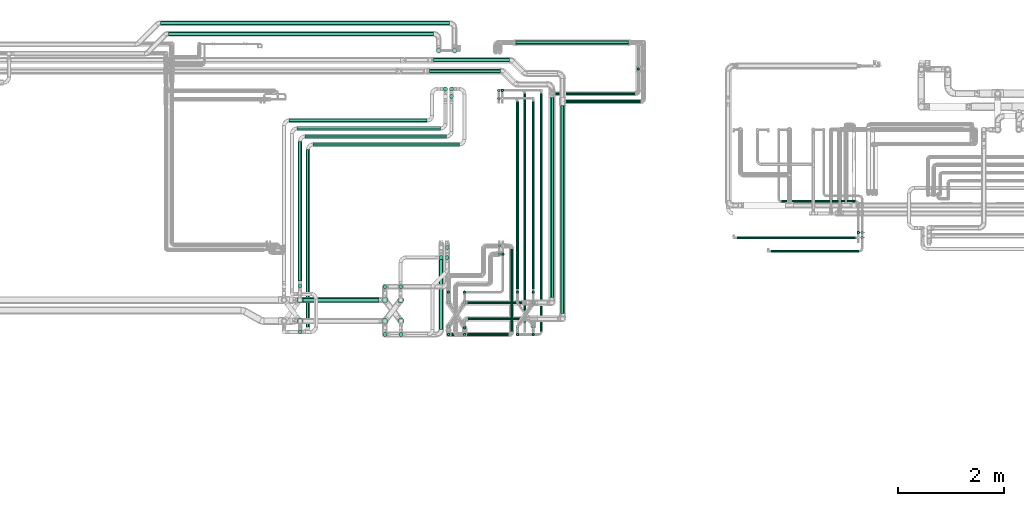
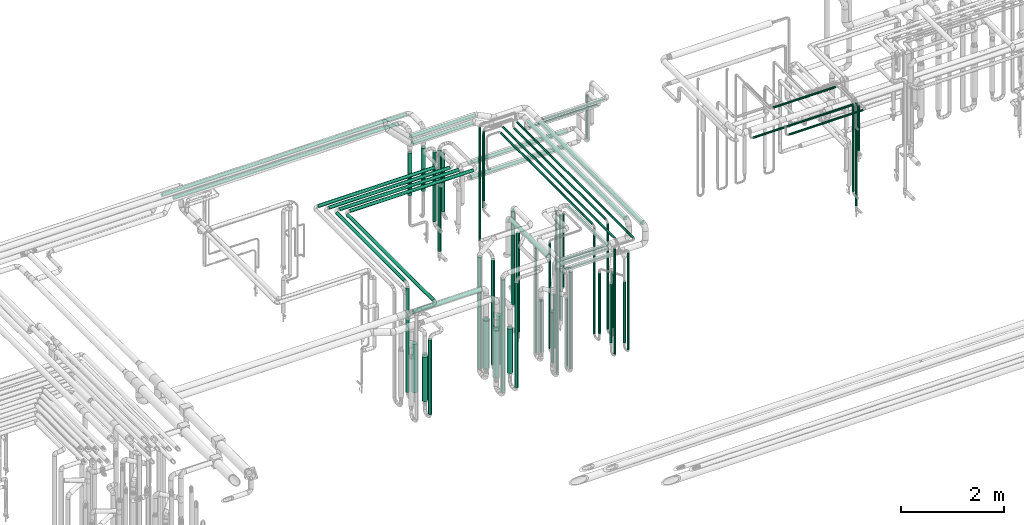
# One storey, part 540 of 827: 75 flow segments.
"""IFC2X3 building model written with IfcOpenShell, lengths in millimetres."""

import ifcopenshell
import ifcopenshell.guid

model = None  # the IFC model being written
_history = None  # IfcOwnerHistory: only IFC2X3 demands one
_inside = {}  # id of a spatial element -> (the spatial element, [elements in it])
_under = {}  # id of a project, library or spatial element -> (it, [spatial elements below it])
_declared = {}  # id of a project -> (the project, [libraries it declares])
_typed = {}  # id of a type object -> (the type object, [elements of that type])
_made_of = {}  # id of a material, layer set ... -> (it, [elements and type objects made of it])


def new_model(schema):
    """Start an empty IFC model of exactly this schema.

    Asked for "IFC4X3", IfcOpenShell would pick the latest addendum, in which some entities
    have other attributes; the version numbers below select the first issue.
    IFC2X3 requires an IfcOwnerHistory on every rooted entity: one is made here for all.
    """
    global model, _history
    if schema == "IFC4X3":
        model = ifcopenshell.file(schema_version=(4, 3, 0, 0))
    else:
        model = ifcopenshell.file(schema=schema)
    _inside.clear()
    _under.clear()
    _declared.clear()
    _typed.clear()
    _made_of.clear()
    _history = None
    if model.schema == "IFC2X3":
        org = make("IfcOrganization", Name="unknown")
        user = make(
            "IfcPersonAndOrganization",
            ThePerson=make("IfcPerson", FamilyName="unknown"),
            TheOrganization=org,
        )
        app = make(
            "IfcApplication",
            ApplicationDeveloper=org,
            Version="unknown",
            ApplicationFullName="unknown",
            ApplicationIdentifier="unknown",
        )
        _history = make(
            "IfcOwnerHistory",
            OwningUser=user,
            OwningApplication=app,
            ChangeAction="ADDED",
            CreationDate=0,
        )
    return model


def make(cls, **values):
    """One entity of the class cls with the attributes given. An attribute that is None is left unset."""
    return model.create_entity(
        cls, **{name: value for name, value in values.items() if value is not None}
    )


def entity(cls, *values):
    """Any entity or typed value of the class cls, its attributes in the order of the schema. None: left unset."""
    e = model.create_entity(cls)
    for i, value in enumerate(values):
        if value is not None:
            e[i] = value
    return e


def rooted(cls, **values):
    """An entity with a GlobalId (a new one), such as an element, a storey or a relation."""
    return make(cls, GlobalId=ifcopenshell.guid.new(), OwnerHistory=_history, **values)


def si_unit(unit_type, name, prefix=None):
    """IfcSIUnit, for example si_unit("LENGTHUNIT", "METRE", prefix="MILLI")."""
    return make("IfcSIUnit", UnitType=unit_type, Prefix=prefix, Name=name)


def converted_unit(unit_type, name, factor, base, dimensions=None, offset=None):
    """IfcConversionBasedUnit, such as the inch: factor (a typed value) times the base unit."""
    return make(
        "IfcConversionBasedUnit"
        if offset is None
        else "IfcConversionBasedUnitWithOffset",
        ConversionOffset=offset,
        Dimensions=None
        if dimensions is None
        else entity("IfcDimensionalExponents", *dimensions),
        UnitType=unit_type,
        Name=name,
        ConversionFactor=make(
            "IfcMeasureWithUnit", ValueComponent=factor, UnitComponent=base
        ),
    )


def derived_unit(unit_type, elements):
    """IfcDerivedUnit: a product of units, each with its exponent."""
    return make(
        "IfcDerivedUnit",
        Elements=[
            make("IfcDerivedUnitElement", Unit=unit, Exponent=power)
            for unit, power in elements
        ],
        UnitType=unit_type,
    )


def assignment(units):
    """IfcUnitAssignment: the units of a project."""
    return None if units is None else make("IfcUnitAssignment", Units=units)


def point(xyz):
    """IfcCartesianPoint."""
    return None if xyz is None else make("IfcCartesianPoint", Coordinates=xyz)


def direction(xyz):
    """IfcDirection."""
    return None if xyz is None else make("IfcDirection", DirectionRatios=xyz)


def frame(location, z_axis=None, x_axis=None):
    """IfcAxis2Placement3D, a coordinate frame: its origin and axes. An axis left out is left unset."""
    return make(
        "IfcAxis2Placement3D",
        Location=point(location),
        Axis=direction(z_axis),
        RefDirection=direction(x_axis),
    )


def frame_2d(location, x_axis=None):
    """IfcAxis2Placement2D, a coordinate frame in the plane: its origin and x axis."""
    return make(
        "IfcAxis2Placement2D", Location=point(location), RefDirection=direction(x_axis)
    )


def origin():
    """The frame at (0, 0, 0) with its axes left unset."""
    return frame((0.0, 0.0, 0.0))


def origin_2d_with_axis():
    """The frame at (0, 0) in the plane with the x axis (1, 0) written out."""
    return frame_2d((0.0, 0.0), x_axis=(1.0, 0.0))


def place(relative_to, where):
    """IfcLocalPlacement: puts the frame where relative to a parent placement (None: the world)."""
    return make(
        "IfcLocalPlacement", PlacementRelTo=relative_to, RelativePlacement=where
    )


def context(
    kind, dimensions, precision=None, world=None, true_north=None, identifier=None
):
    """IfcGeometricRepresentationContext, for example the 3D "Model" context."""
    return make(
        "IfcGeometricRepresentationContext",
        ContextIdentifier=identifier,
        ContextType=kind,
        CoordinateSpaceDimension=dimensions,
        Precision=precision,
        WorldCoordinateSystem=world,
        TrueNorth=true_north,
    )


def subcontext(parent, identifier, kind, view, scale=None):
    """IfcGeometricRepresentationSubContext, for example "Body" below "Model"."""
    return make(
        "IfcGeometricRepresentationSubContext",
        ContextIdentifier=identifier,
        ContextType=kind,
        ParentContext=parent,
        TargetScale=scale,
        TargetView=view,
    )


def project(units=None, contexts=None):
    """IfcProject with its units and contexts."""
    return rooted(
        "IfcProject",
        Name="project",
        RepresentationContexts=contexts,
        UnitsInContext=assignment(units),
    )


def spatial(cls, under=None, at=None, **own):
    """A site, building, storey or space (cls), placed at a placement, below another one or the project."""
    s = rooted(cls, ObjectPlacement=at, **own)
    if under is not None:
        _under.setdefault(under.id(), (under, []))[1].append(s)
    return s


def profile(cls, at=None, kind="AREA", **sizes):
    """A parametric profile (cls). Its sizes go by their IFC names, for example OverallWidth=200.0."""
    return make(cls, ProfileType=kind, Position=at, **sizes)


def circle(**sizes):
    """IfcCircleProfileDef."""
    return profile("IfcCircleProfileDef", **sizes)


def extrude(swept, where, along, depth):
    """IfcExtrudedAreaSolid: the profile swept, set in the frame where, extruded along a direction by depth."""
    return make(
        "IfcExtrudedAreaSolid",
        SweptArea=swept,
        Position=where,
        ExtrudedDirection=direction(along),
        Depth=depth,
    )


def shape(context_of_items, identifier, shape_type, items):
    """IfcShapeRepresentation: the items that make up one representation, for example the "Body"."""
    return make(
        "IfcShapeRepresentation",
        ContextOfItems=context_of_items,
        RepresentationIdentifier=identifier,
        RepresentationType=shape_type,
        Items=items,
    )


def made_of(thing, what):
    """Note that an element or type object is made of a material, layer set ...; save() writes the relation."""
    if what is not None:
        _made_of.setdefault(what.id(), (what, []))[1].append(thing)
    return thing


def type_object(cls, material=None, **own):
    """A type object (cls), such as IfcWallType, which elements share."""
    return made_of(rooted(cls, **own), material)


def element(
    cls,
    number,
    at=None,
    inside=None,
    cuts=None,
    type_object=None,
    material=None,
    context=None,
    identifier="Body",
    shape_type=None,
    held_by="IfcProductDefinitionShape",
    body=None,
    shapes=None,
    **own,
):
    """One element of the class cls, such as IfcWall. Its Tag is "e" and its number.

    at: its placement. inside: the storey or other place that contains it. cuts: it is an
    opening in that element (IfcRelVoidsElement). A single representation is given by context,
    identifier, shape_type and body (its items); several are given by shapes. held_by: the class
    of the entity that holds the representations. save() writes the other relations.
    """
    e = rooted(cls, Tag="e%d" % number, ObjectPlacement=at, **own)
    if body is not None:
        shapes = [shape(context, identifier, shape_type, body)]
    if shapes is not None:
        e.Representation = make(held_by, Representations=shapes)
    if inside is not None:
        _inside.setdefault(inside.id(), (inside, []))[1].append(e)
    if cuts is not None:
        rooted(
            "IfcRelVoidsElement", RelatingBuildingElement=cuts, RelatedOpeningElement=e
        )
    if type_object is not None:
        _typed.setdefault(type_object.id(), (type_object, []))[1].append(e)
    return made_of(e, material)


def aggregate(whole, parts):
    """IfcRelAggregates: a whole, such as a stair, and the parts it consists of."""
    return rooted("IfcRelAggregates", RelatingObject=whole, RelatedObjects=parts)


def save(model, path):
    """Write the relations noted so far, then the file.

    IfcRelAggregates (storeys below a building ...), IfcRelContainedInSpatialStructure (elements
    in a storey), IfcRelDefinesByType, IfcRelAssociatesMaterial and IfcRelDeclares: one each for
    every whole, place, type object, material and project.
    """
    for whole, parts in _under.values():
        aggregate(whole, parts)
    for where, things in _inside.values():
        rooted(
            "IfcRelContainedInSpatialStructure",
            RelatedElements=things,
            RelatingStructure=where,
        )
    for kind, things in _typed.values():
        rooted("IfcRelDefinesByType", RelatedObjects=things, RelatingType=kind)
    for what, things in _made_of.values():
        rooted("IfcRelAssociatesMaterial", RelatedObjects=things, RelatingMaterial=what)
    for by, libraries in _declared.values():
        rooted("IfcRelDeclares", RelatingContext=by, RelatedDefinitions=libraries)
    model.write(path)


model = new_model("IFC2X3")

# Units and contexts
model_context = context("Model", 3, precision=0.01, world=origin(), true_north=direction((6.12303176911189e-17, 1.0)))
body_context = subcontext(model_context, "Body", "Model", "MODEL_VIEW")
ifc_project = project(units=[si_unit("LENGTHUNIT", "METRE", prefix="MILLI"), si_unit("AREAUNIT", "SQUARE_METRE"), si_unit("VOLUMEUNIT", "CUBIC_METRE"), converted_unit("PLANEANGLEUNIT", "DEGREE", entity("IfcRatioMeasure", 0.0174532925199433), si_unit("PLANEANGLEUNIT", "RADIAN"), dimensions=[0, 0, 0, 0, 0, 0, 0]), si_unit("MASSUNIT", "GRAM", prefix="KILO"), derived_unit("MASSDENSITYUNIT", [(si_unit("MASSUNIT", "GRAM", prefix="KILO"), 1), (si_unit("LENGTHUNIT", "METRE"), -3)]), derived_unit("MOMENTOFINERTIAUNIT", [(si_unit("LENGTHUNIT", "METRE"), 4)]), si_unit("TIMEUNIT", "SECOND"), si_unit("FREQUENCYUNIT", "HERTZ"), si_unit("THERMODYNAMICTEMPERATUREUNIT", "DEGREE_CELSIUS"), derived_unit("THERMALTRANSMITTANCEUNIT", [(si_unit("MASSUNIT", "GRAM", prefix="KILO"), 1), (si_unit("THERMODYNAMICTEMPERATUREUNIT", "KELVIN"), -1), (si_unit("TIMEUNIT", "SECOND"), -3)]), derived_unit("VOLUMETRICFLOWRATEUNIT", [(si_unit("LENGTHUNIT", "METRE"), 3), (si_unit("TIMEUNIT", "SECOND"), -1)]), derived_unit("MASSFLOWRATEUNIT", [(si_unit("MASSUNIT", "GRAM", prefix="KILO"), 1), (si_unit("TIMEUNIT", "SECOND"), -1)]), derived_unit("ROTATIONALFREQUENCYUNIT", [(si_unit("TIMEUNIT", "SECOND"), -1)]), si_unit("ELECTRICCURRENTUNIT", "AMPERE"), si_unit("ELECTRICVOLTAGEUNIT", "VOLT"), si_unit("POWERUNIT", "WATT"), si_unit("FORCEUNIT", "NEWTON", prefix="KILO"), si_unit("ILLUMINANCEUNIT", "LUX"), si_unit("LUMINOUSFLUXUNIT", "LUMEN"), si_unit("LUMINOUSINTENSITYUNIT", "CANDELA"), derived_unit("USERDEFINED", [(si_unit("MASSUNIT", "GRAM", prefix="KILO"), -1), (si_unit("LENGTHUNIT", "METRE"), -2), (si_unit("TIMEUNIT", "SECOND"), 3), (si_unit("LUMINOUSFLUXUNIT", "LUMEN"), 1)]), derived_unit("LINEARVELOCITYUNIT", [(si_unit("LENGTHUNIT", "METRE"), 1), (si_unit("TIMEUNIT", "SECOND"), -1)]), si_unit("PRESSUREUNIT", "PASCAL"), derived_unit("USERDEFINED", [(si_unit("LENGTHUNIT", "METRE"), -2), (si_unit("MASSUNIT", "GRAM", prefix="KILO"), 1), (si_unit("TIMEUNIT", "SECOND"), -2)]), derived_unit("LINEARFORCEUNIT", [(si_unit("MASSUNIT", "GRAM", prefix="KILO"), 1), (si_unit("LENGTHUNIT", "METRE"), 1), (si_unit("TIMEUNIT", "SECOND"), -2), (si_unit("LENGTHUNIT", "METRE"), -1)]), derived_unit("PLANARFORCEUNIT", [(si_unit("MASSUNIT", "GRAM", prefix="KILO"), 1), (si_unit("LENGTHUNIT", "METRE"), 1), (si_unit("TIMEUNIT", "SECOND"), -2), (si_unit("LENGTHUNIT", "METRE"), -2)])], contexts=[model_context])

# Site, building, storey
site_placement = place(None, origin())
site = spatial("IfcSite", under=ifc_project, at=site_placement, CompositionType="ELEMENT")
building_placement = place(site_placement, origin())
building = spatial("IfcBuilding", under=site, at=building_placement, CompositionType="ELEMENT")
storey_placement = place(building_placement, frame((0.0, 0.0, 28200.0)))
storey = spatial("IfcBuildingStorey", under=building, at=storey_placement, Name="08", CompositionType="ELEMENT", Elevation=28200.0)

# Flow segments
pipe_segment_type_1 = type_object("IfcPipeSegmentType", PredefinedType="NOTDEFINED")
flow_segment_1_placement = place(storey_placement, frame((41264.57, 19467.64, 2960.4)))
element("IfcFlowSegment", 1, at=flow_segment_1_placement, inside=storey, type_object=pipe_segment_type_1, context=body_context, shape_type="SweptSolid", body=[
    extrude(circle(Radius=38.0, at=origin_2d_with_axis()), frame((0.0, 39.6, 39.6), z_axis=(1.0, 0.0, 0.0), x_axis=(0.0, 1.0, 0.0)), (0.0, 0.0, 1.0), 5448.24882079875),
])
flow_segment_2_placement = place(storey_placement, frame((46761.72, 18945.13, 1487.88)))
element("IfcFlowSegment", 2, at=flow_segment_2_placement, inside=storey, type_object=pipe_segment_type_1, context=body_context, shape_type="SweptSolid", body=[
    extrude(circle(Radius=44.5, at=origin_2d_with_axis()), frame((46.1, 46.1, 0.0), z_axis=(0.0, 0.0, 1.0), x_axis=(-1.0, 0.0, 0.0)), (0.0, 0.0, 1.0), 1017.12499999996),
])
pipe_segment_type_2 = type_object("IfcPipeSegmentType", PredefinedType="NOTDEFINED")
flow_segment_3_placement = place(storey_placement, frame((52778.06, 15183.72, 2973.65)))
element("IfcFlowSegment", 3, at=flow_segment_3_placement, inside=storey, type_object=pipe_segment_type_2, context=body_context, shape_type="SweptSolid", body=[
    extrude(circle(Radius=24.0, at=origin_2d_with_axis()), frame((0.0, 25.6, 25.6), z_axis=(1.0, 0.0, 0.0), x_axis=(0.0, -1.0, 0.0)), (0.0, 0.0, 1.0), 1658.85200000001),
])
flow_segment_4_placement = place(storey_placement, frame((52131.38, 15438.72, 2973.65)))
element("IfcFlowSegment", 4, at=flow_segment_4_placement, inside=storey, type_object=pipe_segment_type_2, context=body_context, shape_type="SweptSolid", body=[
    extrude(circle(Radius=24.0, at=origin_2d_with_axis()), frame((0.0, 25.6, 25.6), z_axis=(1.0, 0.0, 0.0), x_axis=(0.0, 1.0, 0.0)), (0.0, 0.0, 1.0), 2233.49999999993),
])
flow_segment_5_placement = place(storey_placement, frame((52976.38, 16122.34, 2974.4)))
element("IfcFlowSegment", 5, at=flow_segment_5_placement, inside=storey, type_object=pipe_segment_type_2, context=body_context, shape_type="SweptSolid", body=[
    extrude(circle(Radius=24.0, at=origin_2d_with_axis()), frame((0.0, 25.6, 25.6), z_axis=(1.0, 0.0, 0.0), x_axis=(0.0, -1.0, 0.0)), (0.0, 0.0, 1.0), 1388.5),
])
flow_segment_6_placement = place(storey_placement, frame((54468.31, 15438.72, 1878.5)))
element("IfcFlowSegment", 6, at=flow_segment_6_placement, inside=storey, type_object=pipe_segment_type_2, context=body_context, shape_type="SweptSolid", body=[
    extrude(circle(Radius=24.0, at=origin_2d_with_axis()), frame((25.6, 25.6, 0.0)), (0.0, 0.0, 1.0), 1063.74873487189),
])
flow_segment_7_placement = place(storey_placement, frame((54468.31, 15535.15, 514.5)))
element("IfcFlowSegment", 7, at=flow_segment_7_placement, inside=storey, type_object=pipe_segment_type_2, context=body_context, shape_type="SweptSolid", body=[
    extrude(circle(Radius=24.0, at=origin_2d_with_axis()), frame((25.6, 25.6, 0.0)), (0.0, 0.0, 1.0), 2428.50000000001),
])
flow_segment_8_placement = place(storey_placement, frame((54396.29, 15535.44, 877.0)))
element("IfcFlowSegment", 8, at=flow_segment_8_placement, inside=storey, type_object=pipe_segment_type_2, context=body_context, shape_type="SweptSolid", body=[
    extrude(circle(Radius=24.0, at=origin_2d_with_axis()), frame((25.6, 25.6, 0.0)), (0.0, 0.0, 1.0), 2066.00000000001),
])
flow_segment_9_placement = place(storey_placement, frame((48605.5, 14330.68, 2960.65)))
element("IfcFlowSegment", 9, at=flow_segment_9_placement, inside=storey, type_object=pipe_segment_type_2, context=body_context, shape_type="SweptSolid", body=[
    extrude(circle(Radius=37.75, at=origin_2d_with_axis()), frame((39.35, 0.0, 39.35), z_axis=(0.0, 1.0, 0.0), x_axis=(-1.0, 0.0, 0.0)), (0.0, 0.0, 1.0), 3773.85017283484),
])
flow_segment_10_placement = place(storey_placement, frame((46333.17, 18567.35, 2960.65)))
element("IfcFlowSegment", 10, at=flow_segment_10_placement, inside=storey, type_object=pipe_segment_type_2, context=body_context, shape_type="SweptSolid", body=[
    extrude(circle(Radius=37.75, at=origin_2d_with_axis()), frame((0.0, 39.35, 39.35), z_axis=(1.0, 0.0, 0.0), x_axis=(0.0, 1.0, 0.0)), (0.0, 0.0, 1.0), 1341.29942314912),
])
flow_segment_11_placement = place(storey_placement, frame((48805.69, 14028.51, 2960.65)))
element("IfcFlowSegment", 11, at=flow_segment_11_placement, inside=storey, type_object=pipe_segment_type_2, context=body_context, shape_type="SweptSolid", body=[
    extrude(circle(Radius=37.75, at=origin_2d_with_axis()), frame((39.35, 0.0, 39.35), z_axis=(0.0, 1.0, 0.0), x_axis=(-1.0, 0.0, 0.0)), (0.0, 0.0, 1.0), 3926.02173625165),
])
flow_segment_12_placement = place(storey_placement, frame((46413.17, 18770.48, 2960.65)))
element("IfcFlowSegment", 12, at=flow_segment_12_placement, inside=storey, type_object=pipe_segment_type_2, context=body_context, shape_type="SweptSolid", body=[
    extrude(circle(Radius=37.75, at=origin_2d_with_axis()), frame((0.0, 39.35, 39.35), z_axis=(1.0, 0.0, 0.0), x_axis=(0.0, 1.0, 0.0)), (0.0, 0.0, 1.0), 1431.19890326369),
])
flow_segment_13_placement = place(storey_placement, frame((48912.03, 18004.93, 2974.4)))
element("IfcFlowSegment", 13, at=flow_segment_13_placement, inside=storey, type_object=pipe_segment_type_2, context=body_context, shape_type="SweptSolid", body=[
    extrude(circle(Radius=24.0, at=origin_2d_with_axis()), frame((0.0, 25.6, 25.6), z_axis=(1.0, 0.0, 0.0), x_axis=(0.0, -1.0, 0.0)), (0.0, 0.0, 1.0), 1403.0),
])
flow_segment_14_placement = place(storey_placement, frame((48701.84, 18154.93, 2774.4)))
element("IfcFlowSegment", 14, at=flow_segment_14_placement, inside=storey, type_object=pipe_segment_type_2, context=body_context, shape_type="SweptSolid", body=[
    extrude(circle(Radius=24.0, at=origin_2d_with_axis()), frame((0.0, 25.6, 25.6), z_axis=(1.0, 0.0, 0.0), x_axis=(0.0, -1.0, 0.0)), (0.0, 0.0, 1.0), 1513.19134551545),
])
flow_segment_15_placement = place(storey_placement, frame((50246.44, 18614.93, 1707.0)))
element("IfcFlowSegment", 15, at=flow_segment_15_placement, inside=storey, type_object=pipe_segment_type_2, context=body_context, shape_type="SweptSolid", body=[
    extrude(circle(Radius=24.0, at=origin_2d_with_axis()), frame((25.6, 25.6, 0.0)), (0.0, 0.0, 1.0), 1036.00000000006),
])
flow_segment_16_placement = place(storey_placement, frame((47057.67, 13907.91, 2571.86)))
element("IfcFlowSegment", 16, at=flow_segment_16_placement, inside=storey, type_object=pipe_segment_type_2, context=body_context, shape_type="SweptSolid", body=[
    extrude(circle(Radius=24.0, at=origin_2d_with_axis()), frame((0.0, 25.6, 25.6), z_axis=(1.0, 0.0, 0.0), x_axis=(0.0, 1.0, 0.0)), (0.0, 0.0, 1.0), 1048.36321743802),
])
flow_segment_17_placement = place(storey_placement, frame((47053.03, 14210.08, 2579.4)))
element("IfcFlowSegment", 17, at=flow_segment_17_placement, inside=storey, type_object=pipe_segment_type_2, context=body_context, shape_type="SweptSolid", body=[
    extrude(circle(Radius=24.0, at=origin_2d_with_axis()), frame((0.0, 25.6, 25.6), z_axis=(1.0, 0.0, 0.0), x_axis=(0.0, 1.0, 0.0)), (0.0, 0.0, 1.0), 1022.80865450649),
])
flow_segment_18_placement = place(storey_placement, frame((48419.25, 13693.84, 2974.4)))
element("IfcFlowSegment", 18, at=flow_segment_18_placement, inside=storey, type_object=pipe_segment_type_2, context=body_context, shape_type="SweptSolid", body=[
    extrude(circle(Radius=24.0, at=origin_2d_with_axis()), frame((25.6, 0.0, 25.6), z_axis=(0.0, 1.0, 0.0), x_axis=(1.0, 0.0, 0.0)), (0.0, 0.0, 1.0), 4490.04766730808),
])
flow_segment_19_placement = place(storey_placement, frame((48266.43, 14492.0, 2974.4)))
element("IfcFlowSegment", 19, at=flow_segment_19_placement, inside=storey, type_object=pipe_segment_type_2, context=body_context, shape_type="SweptSolid", body=[
    extrude(circle(Radius=24.0, at=origin_2d_with_axis()), frame((25.6, 0.0, 25.6), z_axis=(0.0, 1.0, 0.0), x_axis=(1.0, 0.0, 0.0)), (0.0, 0.0, 1.0), 3540.63515186998),
])
flow_segment_20_placement = place(storey_placement, frame((48102.23, 13859.52, 2974.4)))
element("IfcFlowSegment", 20, at=flow_segment_20_placement, inside=storey, type_object=pipe_segment_type_2, context=body_context, shape_type="SweptSolid", body=[
    extrude(circle(Radius=24.0, at=origin_2d_with_axis()), frame((25.6, 0.01, 25.6), z_axis=(0.000231274334589461, 0.999999973256091, 0.0), x_axis=(0.999999973256091, -0.000231274334589461, 0.0)), (0.0, 0.0, 1.0), 4324.36353367719),
])
flow_segment_21_placement = place(storey_placement, frame((47969.25, 14491.53, 2974.4)))
element("IfcFlowSegment", 21, at=flow_segment_21_placement, inside=storey, type_object=pipe_segment_type_2, context=body_context, shape_type="SweptSolid", body=[
    extrude(circle(Radius=24.0, at=origin_2d_with_axis()), frame((25.6, 0.0, 25.6), z_axis=(0.0, 1.0, 0.0), x_axis=(-1.0, 0.0, 0.0)), (0.0, 0.0, 1.0), 3541.110729783),
])
flow_segment_22_placement = place(storey_placement, frame((47858.42, 13693.84, 2974.4)))
element("IfcFlowSegment", 22, at=flow_segment_22_placement, inside=storey, type_object=pipe_segment_type_2, context=body_context, shape_type="SweptSolid", body=[
    extrude(circle(Radius=24.0, at=origin_2d_with_axis()), frame((25.6, 0.0, 25.6), z_axis=(0.0, 1.0, 0.0), x_axis=(1.0, 0.0, 0.0)), (0.0, 0.0, 1.0), 1556.18693752511),
])
flow_segment_23_placement = place(storey_placement, frame((47969.25, 13611.24, 457.0)))
element("IfcFlowSegment", 23, at=flow_segment_23_placement, inside=storey, type_object=pipe_segment_type_2, context=body_context, shape_type="SweptSolid", body=[
    extrude(circle(Radius=24.0, at=origin_2d_with_axis()), frame((25.6, 25.6, 0.0)), (0.0, 0.0, 1.0), 2486.00000000001),
])
flow_segment_24_placement = place(storey_placement, frame((48266.44, 13611.24, 457.0)))
element("IfcFlowSegment", 24, at=flow_segment_24_placement, inside=storey, type_object=pipe_segment_type_2, context=body_context, shape_type="SweptSolid", body=[
    extrude(circle(Radius=24.0, at=origin_2d_with_axis()), frame((25.6, 25.6, 0.0), z_axis=(0.0, 0.0, 1.0), x_axis=(-1.0, 0.0, 0.0)), (0.0, 0.0, 1.0), 2286.00000000003),
])
flow_segment_25_placement = place(storey_placement, frame((48260.43, 13754.51, 533.0)))
element("IfcFlowSegment", 25, at=flow_segment_25_placement, inside=storey, type_object=pipe_segment_type_2, context=body_context, shape_type="SweptSolid", body=[
    extrude(circle(Radius=30.0, at=origin_2d_with_axis()), frame((31.6, 31.6, 0.0), z_axis=(-2.88181893252549e-06, 4.57694407225587e-07, 1.0), x_axis=(-1.0, 0.0, -2.88181893252579e-06)), (0.0, 0.0, 1.0), 1433.99997704658),
])
flow_segment_26_placement = place(storey_placement, frame((46972.93, 13611.25, 456.99)))
element("IfcFlowSegment", 26, at=flow_segment_26_placement, inside=storey, type_object=pipe_segment_type_2, context=body_context, shape_type="SweptSolid", body=[
    extrude(circle(Radius=24.0, at=origin_2d_with_axis()), frame((25.6, 25.97, 0.0), z_axis=(-2.64985640791711e-08, -0.000162783775417622, 0.999999986750721), x_axis=(-1.0, 0.0, -2.6498564430258e-08)), (0.0, 0.0, 1.0), 2295.79650227157),
])
flow_segment_27_placement = place(storey_placement, frame((46667.19, 13611.24, 457.0)))
element("IfcFlowSegment", 27, at=flow_segment_27_placement, inside=storey, type_object=pipe_segment_type_2, context=body_context, shape_type="SweptSolid", body=[
    extrude(circle(Radius=24.0, at=origin_2d_with_axis()), frame((25.6, 25.6, 0.0)), (0.0, 0.0, 1.0), 2486.00000000002),
])
flow_segment_28_placement = place(storey_placement, frame((45759.1, 13597.63, 445.0)))
element("IfcFlowSegment", 28, at=flow_segment_28_placement, inside=storey, type_object=pipe_segment_type_2, context=body_context, shape_type="SweptSolid", body=[
    extrude(circle(Radius=37.75, at=origin_2d_with_axis()), frame((39.35, 39.35, 0.0)), (0.0, 0.0, 1.0), 2460.0),
])
flow_segment_29_placement = place(storey_placement, frame((45453.93, 13597.49, 445.0)))
element("IfcFlowSegment", 29, at=flow_segment_29_placement, inside=storey, type_object=pipe_segment_type_2, context=body_context, shape_type="SweptSolid", body=[
    extrude(circle(Radius=37.75, at=origin_2d_with_axis()), frame((39.35, 39.35, 0.0)), (0.0, 0.0, 1.0), 2660.05000000001),
])
flow_segment_30_placement = place(storey_placement, frame((48266.43, 14409.41, 457.0)))
element("IfcFlowSegment", 30, at=flow_segment_30_placement, inside=storey, type_object=pipe_segment_type_2, context=body_context, shape_type="SweptSolid", body=[
    extrude(circle(Radius=24.0, at=origin_2d_with_axis()), frame((25.6, 25.6, 0.0)), (0.0, 0.0, 1.0), 2486.00000000002),
])
flow_segment_31_placement = place(storey_placement, frame((47969.25, 14408.93, 457.0)))
element("IfcFlowSegment", 31, at=flow_segment_31_placement, inside=storey, type_object=pipe_segment_type_2, context=body_context, shape_type="SweptSolid", body=[
    extrude(circle(Radius=24.0, at=origin_2d_with_axis()), frame((25.6, 25.6, 0.0)), (0.0, 0.0, 1.0), 2486.00000000001),
])
flow_segment_32_placement = place(storey_placement, frame((46970.44, 14408.93, 457.0)))
element("IfcFlowSegment", 32, at=flow_segment_32_placement, inside=storey, type_object=pipe_segment_type_2, context=body_context, shape_type="SweptSolid", body=[
    extrude(circle(Radius=24.0, at=origin_2d_with_axis()), frame((25.6, 25.6, 0.0)), (0.0, 0.0, 1.0), 2486.00000000002),
])
flow_segment_33_placement = place(storey_placement, frame((46667.19, 14408.93, 457.0)))
element("IfcFlowSegment", 33, at=flow_segment_33_placement, inside=storey, type_object=pipe_segment_type_2, context=body_context, shape_type="SweptSolid", body=[
    extrude(circle(Radius=24.0, at=origin_2d_with_axis()), frame((25.6, 25.6, 0.0)), (0.0, 0.0, 1.0), 2486.00000000001),
])
flow_segment_34_placement = place(storey_placement, frame((45454.88, 14498.73, 445.0)))
element("IfcFlowSegment", 34, at=flow_segment_34_placement, inside=storey, type_object=pipe_segment_type_2, context=body_context, shape_type="SweptSolid", body=[
    extrude(circle(Radius=37.75, at=origin_2d_with_axis()), frame((39.35, 39.35, 0.0), z_axis=(0.0, 0.0, 1.0), x_axis=(-1.0, 0.0, 0.0)), (0.0, 0.0, 1.0), 2637.31109246141),
])
flow_segment_35_placement = place(storey_placement, frame((46749.79, 13611.24, 2974.4)))
element("IfcFlowSegment", 35, at=flow_segment_35_placement, inside=storey, type_object=pipe_segment_type_2, context=body_context, shape_type="SweptSolid", body=[
    extrude(circle(Radius=24.0, at=origin_2d_with_axis()), frame((0.0, 25.6, 25.6), z_axis=(1.0, 0.0, 0.0), x_axis=(0.0, 1.0, 0.0)), (0.0, 0.0, 1.0), 1077.22604286538),
])
flow_segment_36_placement = place(storey_placement, frame((47614.25, 18215.29, 457.0)))
element("IfcFlowSegment", 36, at=flow_segment_36_placement, inside=storey, type_object=pipe_segment_type_2, context=body_context, shape_type="SweptSolid", body=[
    extrude(circle(Radius=24.0, at=origin_2d_with_axis()), frame((25.6, 25.6, 0.0)), (0.0, 0.0, 1.0), 2685.99999970912),
])
flow_segment_37_placement = place(storey_placement, frame((47614.25, 18064.04, 1498.5)))
element("IfcFlowSegment", 37, at=flow_segment_37_placement, inside=storey, type_object=pipe_segment_type_2, context=body_context, shape_type="SweptSolid", body=[
    extrude(circle(Radius=24.0, at=origin_2d_with_axis()), frame((25.6, 25.6, 0.0)), (0.0, 0.0, 1.0), 1644.50064453807),
])
for number, where in (
    (38, (47684.25, 18215.29, 1217.0)),
    (39, (47694.42, 15125.64, 1217.0)),
):
    element("IfcFlowSegment", number, at=place(storey_placement, frame(where)), inside=storey, type_object=pipe_segment_type_2, context=body_context, shape_type="SweptSolid", body=[
        extrude(circle(Radius=24.0, at=origin_2d_with_axis()), frame((25.6, 25.6, 0.0)), (0.0, 0.0, 1.0), 1726.00000000001),
    ])
flow_segment_38_placement = place(storey_placement, frame((47626.15, 15281.43, 1498.5)))
element("IfcFlowSegment", 40, at=flow_segment_38_placement, inside=storey, type_object=pipe_segment_type_2, context=body_context, shape_type="SweptSolid", body=[
    extrude(circle(Radius=24.0, at=origin_2d_with_axis()), frame((25.6, 25.6, 0.0)), (0.0, 0.0, 1.0), 1444.50064453807),
])
flow_segment_39_placement = place(storey_placement, frame((47626.15, 15125.64, 477.25)))
element("IfcFlowSegment", 41, at=flow_segment_39_placement, inside=storey, type_object=pipe_segment_type_2, context=body_context, shape_type="SweptSolid", body=[
    extrude(circle(Radius=24.0, at=origin_2d_with_axis()), frame((25.6, 25.6, 0.0)), (0.0, 0.0, 1.0), 2465.75),
])
flow_segment_40_placement = place(storey_placement, frame((46630.04, 15048.69, 570.0)))
element("IfcFlowSegment", 42, at=flow_segment_40_placement, inside=storey, type_object=pipe_segment_type_2, context=body_context, shape_type="SweptSolid", body=[
    extrude(circle(Radius=37.75, at=origin_2d_with_axis()), frame((39.35, 39.35, 0.0)), (0.0, 0.0, 1.0), 2335.0),
])
flow_segment_41_placement = place(storey_placement, frame((46517.3, 15048.69, 1260.0)))
element("IfcFlowSegment", 43, at=flow_segment_41_placement, inside=storey, type_object=pipe_segment_type_2, context=body_context, shape_type="SweptSolid", body=[
    extrude(circle(Radius=37.75, at=origin_2d_with_axis()), frame((39.35, 39.35, 0.0)), (0.0, 0.0, 1.0), 1645.00000000002),
])
flow_segment_42_placement = place(storey_placement, frame((46517.43, 13731.84, 3160.7)))
element("IfcFlowSegment", 44, at=flow_segment_42_placement, inside=storey, type_object=pipe_segment_type_2, context=body_context, shape_type="SweptSolid", body=[
    extrude(circle(Radius=37.75, at=origin_2d_with_axis()), frame((39.35, 0.0, 39.35), z_axis=(0.0, 1.0, 0.0), x_axis=(-1.0, 0.0, 0.0)), (0.0, 0.0, 1.0), 1448.52294976441),
])
flow_segment_43_placement = place(storey_placement, frame((46631.22, 15238.73, 1518.25)))
element("IfcFlowSegment", 45, at=flow_segment_43_placement, inside=storey, type_object=pipe_segment_type_2, context=body_context, shape_type="SweptSolid", body=[
    extrude(circle(Radius=37.75, at=origin_2d_with_axis()), frame((39.35, 39.35, 0.0)), (0.0, 0.0, 1.0), 1786.75000000002),
])
flow_segment_44_placement = place(storey_placement, frame((43864.22, 14240.77, 2454.15)))
element("IfcFlowSegment", 46, at=flow_segment_44_placement, inside=storey, type_object=pipe_segment_type_2, context=body_context, shape_type="SweptSolid", body=[
    extrude(circle(Radius=44.25, at=origin_2d_with_axis()), frame((0.0, 45.85, 45.85), z_axis=(1.0, 0.0, 0.0), x_axis=(0.0, 1.0, 0.0)), (0.0, 0.0, 1.0), 1516.0),
])
flow_segment_45_placement = place(storey_placement, frame((43858.87, 13647.63, 445.0)))
element("IfcFlowSegment", 47, at=flow_segment_45_placement, inside=storey, type_object=pipe_segment_type_2, context=body_context, shape_type="SweptSolid", body=[
    extrude(circle(Radius=37.75, at=origin_2d_with_axis()), frame((39.35, 39.35, 0.0), z_axis=(0.0, 0.0, 1.0), x_axis=(-1.0, 0.0, 0.0)), (0.0, 0.0, 1.0), 1759.99999999999),
])
flow_segment_46_placement = place(storey_placement, frame((43855.69, 14511.23, 445.0)))
element("IfcFlowSegment", 48, at=flow_segment_46_placement, inside=storey, type_object=pipe_segment_type_2, context=body_context, shape_type="SweptSolid", body=[
    extrude(circle(Radius=37.75, at=origin_2d_with_axis()), frame((39.35, 39.35, 0.0)), (0.0, 0.0, 1.0), 2459.99999999997),
])
flow_segment_47_placement = place(storey_placement, frame((43855.69, 14645.58, 2960.65)))
element("IfcFlowSegment", 49, at=flow_segment_47_placement, inside=storey, type_object=pipe_segment_type_2, context=body_context, shape_type="SweptSolid", body=[
    extrude(circle(Radius=37.75, at=origin_2d_with_axis()), frame((39.35, 0.0, 39.35), z_axis=(0.0, 1.0, 0.0), x_axis=(1.0, 0.0, 0.0)), (0.0, 0.0, 1.0), 2630.65846247453),
])
flow_segment_48_placement = place(storey_placement, frame((43990.03, 17331.89, 2960.65)))
element("IfcFlowSegment", 50, at=flow_segment_48_placement, inside=storey, type_object=pipe_segment_type_2, context=body_context, shape_type="SweptSolid", body=[
    extrude(circle(Radius=37.75, at=origin_2d_with_axis()), frame((0.0, 39.35, 39.35), z_axis=(1.0, 0.0, 0.0), x_axis=(0.0, -1.0, 0.0)), (0.0, 0.0, 1.0), 2667.04065000001),
])
flow_segment_49_placement = place(storey_placement, frame((44005.69, 13781.84, 2960.65)))
element("IfcFlowSegment", 51, at=flow_segment_49_placement, inside=storey, type_object=pipe_segment_type_2, context=body_context, shape_type="SweptSolid", body=[
    extrude(circle(Radius=37.75, at=origin_2d_with_axis()), frame((39.35, 0.0, 39.35), z_axis=(0.0, 1.0, 0.0), x_axis=(1.0, 0.0, 0.0)), (0.0, 0.0, 1.0), 3343.39766600003),
])
flow_segment_50_placement = place(storey_placement, frame((44140.03, 17180.89, 2960.65)))
element("IfcFlowSegment", 52, at=flow_segment_50_placement, inside=storey, type_object=pipe_segment_type_2, context=body_context, shape_type="SweptSolid", body=[
    extrude(circle(Radius=37.75, at=origin_2d_with_axis()), frame((0.0, 39.35, 39.35), z_axis=(1.0, 0.0, 0.0), x_axis=(0.0, -1.0, 0.0)), (0.0, 0.0, 1.0), 2757.04065000002),
])
flow_segment_51_placement = place(storey_placement, frame((43840.03, 17481.69, 2960.65)))
element("IfcFlowSegment", 53, at=flow_segment_51_placement, inside=storey, type_object=pipe_segment_type_2, context=body_context, shape_type="SweptSolid", body=[
    extrude(circle(Radius=37.75, at=origin_2d_with_axis()), frame((0.0, 39.35, 39.35), z_axis=(1.0, 0.0, 0.0), x_axis=(0.0, -1.0, 0.0)), (0.0, 0.0, 1.0), 2702.99999970258),
])
flow_segment_52_placement = place(storey_placement, frame((43690.03, 17631.89, 2960.65)))
element("IfcFlowSegment", 54, at=flow_segment_52_placement, inside=storey, type_object=pipe_segment_type_2, context=body_context, shape_type="SweptSolid", body=[
    extrude(circle(Radius=37.75, at=origin_2d_with_axis()), frame((0.0, 39.35, 39.35), z_axis=(1.0, 0.0, 0.0), x_axis=(0.0, -1.0, 0.0)), (0.0, 0.0, 1.0), 2600.00000000001),
])
flow_segment_53_placement = place(storey_placement, frame((46712.73, 18226.89, 521.0)))
element("IfcFlowSegment", 55, at=flow_segment_53_placement, inside=storey, type_object=pipe_segment_type_2, context=body_context, shape_type="SweptSolid", body=[
    extrude(circle(Radius=37.75, at=origin_2d_with_axis()), frame((39.35, 39.35, 0.0)), (0.0, 0.0, 1.0), 2383.99999999987),
])
flow_segment_54_placement = place(storey_placement, frame((46712.73, 18086.23, 1537.25)))
element("IfcFlowSegment", 56, at=flow_segment_54_placement, inside=storey, type_object=pipe_segment_type_2, context=body_context, shape_type="SweptSolid", body=[
    extrude(circle(Radius=37.75, at=origin_2d_with_axis()), frame((39.35, 39.35, 0.0)), (0.0, 0.0, 1.0), 1367.75000000003),
])
flow_segment_55_placement = place(storey_placement, frame((41411.59, 19267.89, 2960.65)))
element("IfcFlowSegment", 57, at=flow_segment_55_placement, inside=storey, type_object=pipe_segment_type_2, context=body_context, shape_type="SweptSolid", body=[
    extrude(circle(Radius=37.75, at=origin_2d_with_axis()), frame((0.0, 39.35, 39.35), z_axis=(1.0, 0.0, 0.0), x_axis=(0.0, -1.0, 0.0)), (0.0, 0.0, 1.0), 5001.22814555646),
])
flow_segment_56_placement = place(storey_placement, frame((46964.44, 14204.08, 586.0)))
element("IfcFlowSegment", 58, at=flow_segment_56_placement, inside=storey, type_object=pipe_segment_type_2, context=body_context, shape_type="SweptSolid", body=[
    extrude(circle(Radius=30.0, at=origin_2d_with_axis()), frame((31.6, 31.6, 0.0), z_axis=(0.0, 0.0, 1.0), x_axis=(-1.0, 0.0, 0.0)), (0.0, 0.0, 1.0), 1262.99999999999),
])
flow_segment_57_placement = place(storey_placement, frame((46972.93, 13738.17, 457.0)))
element("IfcFlowSegment", 59, at=flow_segment_57_placement, inside=storey, type_object=pipe_segment_type_2, context=body_context, shape_type="SweptSolid", body=[
    extrude(circle(Radius=24.0, at=origin_2d_with_axis()), frame((25.6, 25.6, 0.0), z_axis=(0.0, 0.0, 1.0), x_axis=(-1.0, 0.0, 0.0)), (0.0, 0.0, 1.0), 1586.11232988612),
])
flow_segment_58_placement = place(storey_placement, frame((46661.19, 14207.93, 586.0)))
element("IfcFlowSegment", 60, at=flow_segment_58_placement, inside=storey, type_object=pipe_segment_type_2, context=body_context, shape_type="SweptSolid", body=[
    extrude(circle(Radius=30.0, at=origin_2d_with_axis()), frame((31.6, 31.6, 0.0), z_axis=(0.0, 0.0, 1.0), x_axis=(-1.0, 0.0, 0.0)), (0.0, 0.0, 1.0), 1235.49999999998),
])
flow_segment_59_placement = place(storey_placement, frame((46661.19, 13756.91, 617.02)))
element("IfcFlowSegment", 61, at=flow_segment_59_placement, inside=storey, type_object=pipe_segment_type_2, context=body_context, shape_type="SweptSolid", body=[
    extrude(circle(Radius=30.0, at=origin_2d_with_axis()), frame((31.6, 31.6, 0.0), z_axis=(0.0, 0.0, 1.0), x_axis=(-1.0, 0.0, 0.0)), (0.0, 0.0, 1.0), 1204.4784639113),
])
flow_segment_60_placement = place(storey_placement, frame((47950.3, 19101.88, 1260.65)))
element("IfcFlowSegment", 62, at=flow_segment_60_placement, inside=storey, type_object=pipe_segment_type_2, context=body_context, shape_type="SweptSolid", body=[
    extrude(circle(Radius=37.75, at=origin_2d_with_axis()), frame((0.0, 39.35, 39.35), z_axis=(1.0, 0.0, 0.0), x_axis=(0.0, 1.0, 0.0)), (0.0, 0.0, 1.0), 2145.73797712595),
])
flow_segment_61_placement = place(storey_placement, frame((47963.3, 19101.88, 1610.65)))
element("IfcFlowSegment", 63, at=flow_segment_61_placement, inside=storey, type_object=pipe_segment_type_2, context=body_context, shape_type="SweptSolid", body=[
    extrude(circle(Radius=37.75, at=origin_2d_with_axis()), frame((0.0, 39.35, 39.35), z_axis=(1.0, 0.0, 0.0), x_axis=(0.0, -1.0, 0.0)), (0.0, 0.0, 1.0), 2120.0),
])
flow_segment_62_placement = place(storey_placement, frame((46598.69, 18226.89, 1260.0)))
element("IfcFlowSegment", 64, at=flow_segment_62_placement, inside=storey, type_object=pipe_segment_type_2, context=body_context, shape_type="SweptSolid", body=[
    extrude(circle(Radius=37.75, at=origin_2d_with_axis()), frame((39.35, 39.35, 0.0), z_axis=(0.0, 0.0, 1.0), x_axis=(-1.0, 0.0, 0.0)), (0.0, 0.0, 1.0), 1644.99999999999),
])
flow_segment_63_placement = place(storey_placement, frame((45434.68, 13831.58, 643.02)))
element("IfcFlowSegment", 65, at=flow_segment_63_placement, inside=storey, type_object=pipe_segment_type_2, context=body_context, shape_type="SweptSolid", body=[
    extrude(circle(Radius=57.0, at=origin_2d_with_axis()), frame((58.6, 58.6, 0.0), z_axis=(0.0, 0.0, 1.0), x_axis=(-1.0, 0.0, 0.0)), (0.0, 0.0, 1.0), 1114.97846391128),
])
flow_segment_64_placement = place(storey_placement, frame((45435.63, 14228.02, 612.0)))
element("IfcFlowSegment", 66, at=flow_segment_64_placement, inside=storey, type_object=pipe_segment_type_2, context=body_context, shape_type="SweptSolid", body=[
    extrude(circle(Radius=57.0, at=origin_2d_with_axis()), frame((58.6, 58.6, 0.0), z_axis=(0.0, 0.0, 1.0), x_axis=(-1.0, 0.0, 0.0)), (0.0, 0.0, 1.0), 1140.0),
])
flow_segment_65_placement = place(storey_placement, frame((45739.85, 13830.22, 643.02)))
element("IfcFlowSegment", 67, at=flow_segment_65_placement, inside=storey, type_object=pipe_segment_type_2, context=body_context, shape_type="SweptSolid", body=[
    extrude(circle(Radius=57.0, at=origin_2d_with_axis()), frame((58.6, 58.6, 0.0), z_axis=(0.0, 0.0, 1.0), x_axis=(-1.0, 0.0, 0.0)), (0.0, 0.0, 1.0), 1050.17846391129),
])
flow_segment_66_placement = place(storey_placement, frame((45734.48, 14228.02, 612.0)))
element("IfcFlowSegment", 68, at=flow_segment_66_placement, inside=storey, type_object=pipe_segment_type_2, context=body_context, shape_type="SweptSolid", body=[
    extrude(circle(Radius=57.0, at=origin_2d_with_axis()), frame((58.6, 58.6, 0.0), z_axis=(0.0, 0.0, 1.0), x_axis=(-1.0, 0.0, 0.0)), (0.0, 0.0, 1.0), 1145.99999999996),
])
flow_segment_67_placement = place(storey_placement, frame((45753.73, 14498.73, 445.0)))
element("IfcFlowSegment", 69, at=flow_segment_67_placement, inside=storey, type_object=pipe_segment_type_2, context=body_context, shape_type="SweptSolid", body=[
    extrude(circle(Radius=37.75, at=origin_2d_with_axis()), frame((39.35, 39.35, 0.0), z_axis=(0.0, 0.0, 1.0), x_axis=(-1.0, 0.0, 0.0)), (0.0, 0.0, 1.0), 2460.0),
])
flow_segment_68_placement = place(storey_placement, frame((47963.25, 13754.6, 636.0)))
element("IfcFlowSegment", 70, at=flow_segment_68_placement, inside=storey, type_object=pipe_segment_type_2, context=body_context, shape_type="SweptSolid", body=[
    extrude(circle(Radius=30.0, at=origin_2d_with_axis()), frame((31.6, 31.6, 0.0), z_axis=(0.0, 0.0, 1.0), x_axis=(-1.0, 0.0, 0.0)), (0.0, 0.0, 1.0), 1388.00000000001),
])
flow_segment_69_placement = place(storey_placement, frame((47963.25, 14204.08, 586.0)))
element("IfcFlowSegment", 71, at=flow_segment_69_placement, inside=storey, type_object=pipe_segment_type_2, context=body_context, shape_type="SweptSolid", body=[
    extrude(circle(Radius=30.0, at=origin_2d_with_axis()), frame((31.6, 31.6, 0.0), z_axis=(0.0, 0.0, 1.0), x_axis=(-1.0, 0.0, 0.0)), (0.0, 0.0, 1.0), 1424.0),
])
flow_segment_70_placement = place(storey_placement, frame((48260.43, 14204.08, 617.02)))
element("IfcFlowSegment", 72, at=flow_segment_70_placement, inside=storey, type_object=pipe_segment_type_2, context=body_context, shape_type="SweptSolid", body=[
    extrude(circle(Radius=30.0, at=origin_2d_with_axis()), frame((31.6, 31.6, 0.0), z_axis=(0.0, 0.0, 1.0), x_axis=(-1.0, 0.0, 0.0)), (0.0, 0.0, 1.0), 1304.4784639113),
])
flow_segment_71_placement = place(storey_placement, frame((43839.62, 13831.58, 643.02)))
element("IfcFlowSegment", 73, at=flow_segment_71_placement, inside=storey, type_object=pipe_segment_type_2, context=body_context, shape_type="SweptSolid", body=[
    extrude(circle(Radius=57.0, at=origin_2d_with_axis()), frame((58.6, 58.6, 0.0)), (0.0, 0.0, 1.0), 1050.17846391129),
])
flow_segment_72_placement = place(storey_placement, frame((43835.95, 14228.39, 611.97)))
element("IfcFlowSegment", 74, at=flow_segment_72_placement, inside=storey, type_object=pipe_segment_type_2, context=body_context, shape_type="SweptSolid", body=[
    extrude(circle(Radius=57.0, at=origin_2d_with_axis()), frame((59.13, 58.6, 0.03), z_axis=(-0.000462463929099555, 0.0, 0.999999893063552), x_axis=(-0.999999893063552, 0.0, -0.000462463929099555)), (0.0, 0.0, 1.0), 1146.00012254914),
])
flow_segment_73_placement = place(storey_placement, frame((46461.97, 18945.38, 1487.88)))
element("IfcFlowSegment", 75, at=flow_segment_73_placement, inside=storey, type_object=pipe_segment_type_2, context=body_context, shape_type="SweptSolid", body=[
    extrude(circle(Radius=44.25, at=origin_2d_with_axis()), frame((45.85, 45.85, 0.0), z_axis=(0.0, 0.0, 1.0), x_axis=(-1.0, 0.0, 0.0)), (0.0, 0.0, 1.0), 1003.12499999997),
])

save(model, "model.ifc")
